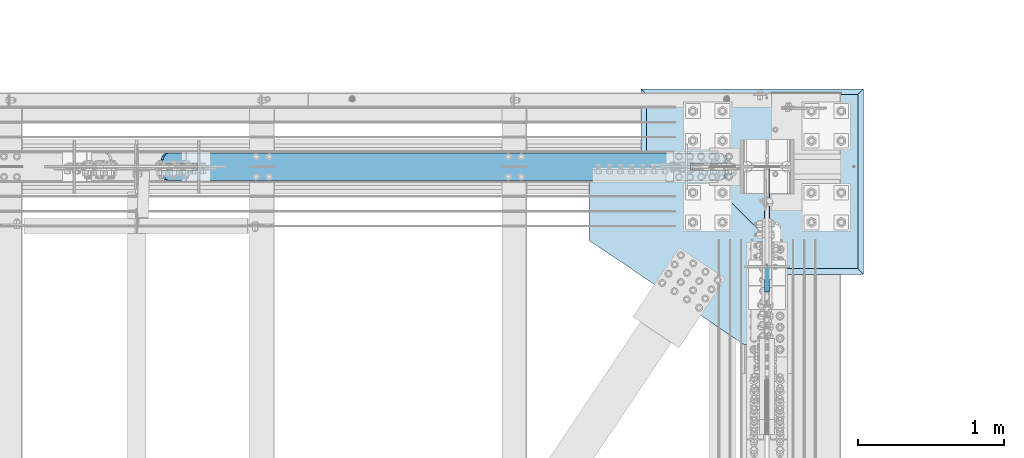
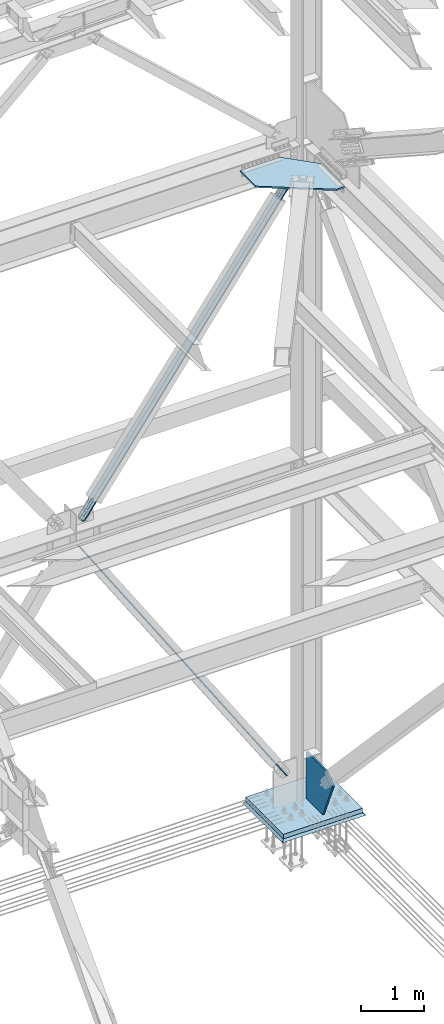
# One storey, part 3007 of 3843: 6 plates, 5 elements without a shape of their own.
"""IFC2X3 building model written with IfcOpenShell, lengths in millimetres."""

from ifc_helpers import new_model, si_unit, frame, origin_with_axes, place, context, subcontext, project, spatial, faceted_brep, material, type_object, element, aggregate, save


model = new_model("IFC2X3")

# Units and contexts
model_context = context("Model", 3, precision=1e-05, world=origin_with_axes())
body_context = subcontext(model_context, "Body", "Model", "MODEL_VIEW")
ifc_project = project(units=[si_unit("LENGTHUNIT", "METRE", prefix="MILLI"), si_unit("AREAUNIT", "SQUARE_METRE"), si_unit("VOLUMEUNIT", "CUBIC_METRE"), si_unit("MASSUNIT", "GRAM", prefix="KILO"), si_unit("TIMEUNIT", "SECOND"), si_unit("PLANEANGLEUNIT", "RADIAN"), si_unit("SOLIDANGLEUNIT", "STERADIAN"), si_unit("THERMODYNAMICTEMPERATUREUNIT", "DEGREE_CELSIUS"), si_unit("LUMINOUSINTENSITYUNIT", "LUMEN")], contexts=[model_context])

# Site, building, storey
site_placement = place(None, origin_with_axes())
site = spatial("IfcSite", under=ifc_project, at=site_placement, CompositionType="ELEMENT")
building_placement = place(site_placement, origin_with_axes())
building = spatial("IfcBuilding", under=site, at=building_placement, Name="Undefined", CompositionType="ELEMENT")
storey_placement = place(building_placement, origin_with_axes())
storey = spatial("IfcBuildingStorey", under=building, at=storey_placement, Name="Undefined", CompositionType="ELEMENT", Elevation=0.0)

# Assembly, plate
assembly_1_placement = place(storey_placement, origin_with_axes())
assembly_1 = element("IfcElementAssembly", 1, at=assembly_1_placement, inside=storey, Name="CB", AssemblyPlace="NOTDEFINED", PredefinedType="RIGID_FRAME")
ifc_material_1 = material(Name="STEEL/A36")
plate_type_1 = type_object("IfcPlateType", PredefinedType="NOTDEFINED")
plate_1_placement = place(assembly_1_placement, frame((81514.0571048379, 104465.4375, 36504.4653808868), z_axis=(0.587657745235489, 0.0, 0.809109618324206), x_axis=(0.0, 1.0, 0.0)))
plate_1 = element("IfcPlate", 2, at=plate_1_placement, type_object=plate_type_1, material=ifc_material_1, Name="CB", context=body_context, shape_type="Brep", body=[
    faceted_brep([(0.0, -9.52500000005239, 71.437499999869), (0.0, -9.52499995547259, 6493.07598148154), (0.0, 9.52500004445756, 6493.07598148161), (0.0, 9.52499999999418, 71.4374999997672), (5.43785589621984, -9.52499995529797, 6520.41392918109), (5.43785589621984, 9.52500004466128, 6520.41392918116), (20.9235593189806, -9.5249999551379, 6543.58992216249), (20.9235593189806, 9.52500004482135, 6543.58992216254), (44.099552300424, -9.52499995502876, 6559.07562558522), (44.099552300424, 9.52500004491594, 6559.07562558529), (71.4375, -9.52499995498511, 6564.51348148144), (71.4375, 9.52500004494505, 6564.51348148151), (71.4375, -9.52499995778635, 6155.63174068234), (71.4375, 9.52500004215108, 6155.63174068239), (115.887500000012, -9.52499995778635, 6155.63174068234), (115.887500000012, 9.52500004215108, 6155.63174068239), (115.887500000012, -9.52499995498511, 6564.51348148144), (115.887500000012, 9.52500004494505, 6564.51348148151), (143.225447699588, -9.52499995502876, 6559.07562558522), (143.225447699588, 9.52500004491594, 6559.07562558529), (166.401440681031, -9.5249999551379, 6543.58992216249), (166.401440681031, 9.52500004482135, 6543.58992216254), (181.887144103792, -9.52499995529797, 6520.41392918109), (181.887144103792, 9.52500004466128, 6520.41392918116), (187.325000000012, -9.52499995547259, 6493.07598148154), (187.325000000012, 9.52500004445756, 6493.07598148161), (187.325000000012, -9.52500000005239, 71.437499999869), (187.325000000012, 9.52499999999418, 71.4374999997672), (181.887144103792, -9.52500000003783, 44.0995523003512), (181.887144103792, 9.52500000001601, 44.0995523002639), (166.401440681031, -9.52500000002328, 20.9235593189806), (166.401440681031, 9.52500000002328, 20.9235593188787), (143.225447699588, -9.52500000002328, 5.4378558962635), (143.225447699588, 9.52500000002328, 5.43785589616164), (115.887500000012, -9.52500000002328, 4.36557456851006e-11), (115.887500000012, 9.52500000002328, -5.82076609134674e-11), (115.887500000012, -9.5250000001397, 408.881740811397), (115.887500000012, 9.52499999990687, 408.88174081131), (71.4375, -9.5250000001397, 408.881740811397), (71.4375, 9.52499999990687, 408.88174081131), (71.4375, -9.52500000002328, 4.36557456851006e-11), (71.4375, 9.52500000002328, -5.82076609134674e-11), (44.099552300424, -9.52500000002328, 5.4378558962635), (44.099552300424, 9.52500000002328, 5.43785589616164), (20.9235593189806, -9.52500000002328, 20.9235593189806), (20.9235593189806, 9.52500000002328, 20.9235593188787), (5.43785589621984, -9.52500000003783, 44.0995523003512), (5.43785589621984, 9.52500000001601, 44.0995523002639)], [[[0, 1, 2, 3]], [[1, 4, 5, 2]], [[4, 6, 7, 5]], [[6, 8, 9, 7]], [[8, 10, 11, 9]], [[10, 12, 13, 11]], [[12, 14, 15, 13]], [[14, 16, 17, 15]], [[16, 18, 19, 17]], [[18, 20, 21, 19]], [[20, 22, 23, 21]], [[22, 24, 25, 23]], [[24, 26, 27, 25]], [[26, 28, 29, 27]], [[28, 30, 31, 29]], [[30, 32, 33, 31]], [[32, 34, 35, 33]], [[34, 36, 37, 35]], [[36, 38, 39, 37]], [[38, 40, 41, 39]], [[40, 42, 43, 41]], [[42, 44, 45, 43]], [[44, 46, 47, 45]], [[46, 0, 3, 47]], [[5, 7, 9, 11, 13, 15, 17, 19, 21, 23, 25, 27, 29, 31, 33, 35, 37, 39, 41, 43, 45, 47, 3, 2]], [[46, 44, 42, 40, 38, 36, 34, 32, 30, 28, 26, 24, 22, 20, 18, 16, 14, 12, 10, 8, 6, 4, 1, 0]]]),
])
aggregate(assembly_1, [plate_1])

assembly_2_placement = place(storey_placement, origin_with_axes())
assembly_2 = element("IfcElementAssembly", 3, at=assembly_2_placement, inside=storey, Name="CB", AssemblyPlace="NOTDEFINED", PredefinedType="RIGID_FRAME")
plate_2_placement = place(assembly_2_placement, frame((85266.1018467478, 104652.7625, 30273.963518513), z_axis=(-0.549839243795952, 0.0, 0.835270498690032), x_axis=(0.0, -1.0, 0.0)))
plate_2 = element("IfcPlate", 4, at=plate_2_placement, type_object=plate_type_1, material=ifc_material_1, Name="CB", context=body_context, shape_type="Brep", body=[
    faceted_brep([(0.0, -9.52500000005239, 71.437499999869), (0.0, -9.5250000347005, 6772.47598159187), (0.0, 9.52499996528059, 6772.47598159185), (0.0, 9.52499999999418, 71.4374999997672), (5.43785589621984, -9.52500003485329, 6799.81392929154), (5.43785589621984, 9.52499996514962, 6799.81392929153), (20.9235593189806, -9.52500003495516, 6822.98992227305), (20.9235593189806, 9.5249999650332, 6822.98992227303), (44.099552300424, -9.52500003503519, 6838.47562569586), (44.099552300424, 9.52499996494589, 6838.47562569585), (71.4375, -9.52500003506429, 6843.91348159211), (71.4375, 9.52499996493134, 6843.9134815921), (71.4375, -9.52500003296154, 6435.03174078606), (71.4375, 9.52499996702682, 6435.03174078604), (115.887500000012, -9.52500003296154, 6435.03174078606), (115.887500000012, 9.52499996702682, 6435.03174078604), (115.887500000012, -9.52500003506429, 6843.91348159211), (115.887500000012, 9.52499996493134, 6843.9134815921), (143.225447699588, -9.52500003503519, 6838.47562569586), (143.225447699588, 9.52499996494589, 6838.47562569585), (166.401440681031, -9.52500003495516, 6822.98992227305), (166.401440681031, 9.5249999650332, 6822.98992227303), (181.887144103792, -9.52500003485329, 6799.81392929154), (181.887144103792, 9.52499996514962, 6799.81392929153), (187.325000000012, -9.5250000347005, 6772.47598159187), (187.325000000012, 9.52499996528059, 6772.47598159185), (187.325000000012, -9.52500000005239, 71.437499999869), (187.325000000012, 9.52499999999418, 71.4374999997672), (181.887144103792, -9.52500000003783, 44.0995523003512), (181.887144103792, 9.52500000001601, 44.0995523002639), (166.401440681031, -9.52500000002328, 20.9235593189806), (166.401440681031, 9.52500000002328, 20.9235593188787), (143.225447699588, -9.52500000002328, 5.4378558962635), (143.225447699588, 9.52500000002328, 5.43785589616164), (115.887500000012, -9.52500000002328, 4.36557456851006e-11), (115.887500000012, 9.52500000002328, -5.82076609134674e-11), (115.887500000012, -9.5250000001397, 408.881740811397), (115.887500000012, 9.52499999990687, 408.88174081131), (71.4375, -9.5250000001397, 408.881740811397), (71.4375, 9.52499999990687, 408.88174081131), (71.4375, -9.52500000002328, 4.36557456851006e-11), (71.4375, 9.52500000002328, -5.82076609134674e-11), (44.099552300424, -9.52500000002328, 5.4378558962635), (44.099552300424, 9.52500000002328, 5.43785589616164), (20.9235593189806, -9.52500000002328, 20.9235593189806), (20.9235593189806, 9.52500000002328, 20.9235593188787), (5.43785589621984, -9.52500000003783, 44.0995523003512), (5.43785589621984, 9.52500000001601, 44.0995523002639)], [[[0, 1, 2, 3]], [[1, 4, 5, 2]], [[4, 6, 7, 5]], [[6, 8, 9, 7]], [[8, 10, 11, 9]], [[10, 12, 13, 11]], [[12, 14, 15, 13]], [[14, 16, 17, 15]], [[16, 18, 19, 17]], [[18, 20, 21, 19]], [[20, 22, 23, 21]], [[22, 24, 25, 23]], [[24, 26, 27, 25]], [[26, 28, 29, 27]], [[28, 30, 31, 29]], [[30, 32, 33, 31]], [[32, 34, 35, 33]], [[34, 36, 37, 35]], [[36, 38, 39, 37]], [[38, 40, 41, 39]], [[40, 42, 43, 41]], [[42, 44, 45, 43]], [[44, 46, 47, 45]], [[46, 0, 3, 47]], [[5, 7, 9, 11, 13, 15, 17, 19, 21, 23, 25, 27, 29, 31, 33, 35, 37, 39, 41, 43, 45, 47, 3, 2]], [[46, 44, 42, 40, 38, 36, 34, 32, 30, 28, 26, 24, 22, 20, 18, 16, 14, 12, 10, 8, 6, 4, 1, 0]]]),
])
aggregate(assembly_2, [plate_2])

assembly_3_placement = place(storey_placement, origin_with_axes())
assembly_3 = element("IfcElementAssembly", 5, at=assembly_3_placement, inside=storey, Name="PLATE", AssemblyPlace="NOTDEFINED", PredefinedType="RIGID_FRAME")
ifc_material_2 = material(Name="STEEL/A572-50")
plate_type_2 = type_object("IfcPlateType", PredefinedType="NOTDEFINED")
plate_3_placement = place(assembly_3_placement, frame((85166.2, 104552.750000036, 42232.2630004883), z_axis=(0.0, -1.0, 0.0), x_axis=(-1.0, 0.0, 0.0)))
plate_3 = element("IfcPlate", 6, at=plate_3_placement, type_object=plate_type_2, material=ifc_material_2, Name="PLATE", context=body_context, shape_type="Brep", body=[
    faceted_brep([(0.0, -14.2874999999985, 0.0), (-476.24999999853, -14.2874999999985, 476.24999999311), (-476.24999999853, 14.2874999999985, 476.24999999311), (0.0, 14.2874999999985, 0.0), (-476.24999999853, -14.2874999999985, 1212.85000000025), (-476.24999999853, 14.2874999999985, 1212.85000000025), (-327.024999999998, -14.2874999999985, 1212.85000000949), (-327.024999999998, 14.2874999999985, 1212.85000000949), (736.599999999977, -14.2874999999985, 499.389608647441), (736.599999999977, 14.2874999999985, 499.389608647441), (736.599999940488, -14.2874999999985, 0.0), (736.599999940488, 14.2874999999985, 0.0)], [[[0, 1, 2, 3]], [[1, 4, 5, 2]], [[4, 6, 7, 5]], [[6, 8, 9, 7]], [[8, 10, 11, 9]], [[10, 0, 3, 11]], [[5, 7, 9, 11, 3, 2]], [[10, 8, 6, 4, 1, 0]]]),
])
aggregate(assembly_3, [plate_3])

assembly_4_placement = place(storey_placement, origin_with_axes())
assembly_4 = element("IfcElementAssembly", 7, at=assembly_4_placement, inside=storey, Name="COLUMN", AssemblyPlace="NOTDEFINED", PredefinedType="RIGID_FRAME")
plate_type_3 = type_object("IfcPlateType", PredefinedType="NOTDEFINED")
plate_4_placement = place(assembly_4_placement, frame((85648.8, 104551.95625, 29692.6), z_axis=(0.0, 0.0, 1.0), x_axis=(0.0, -1.0, 0.0)))
plate_4 = element("IfcPlate", 8, at=plate_4_placement, type_object=plate_type_3, material=ifc_material_2, Name="CB", context=body_context, shape_type="Brep", body=[
    faceted_brep([(0.0, -15.875, 19.0499992370605), (0.0, -15.875, 888.895145418875), (0.0, 15.875, 888.895145418875), (0.0, 15.875, 19.0499992370605), (19.0499992370605, -15.875, 907.945144655936), (19.0499992370605, 15.875, 907.945144655936), (663.438174577459, -15.875, 907.945144655936), (663.438174577459, 15.875, 907.945144655936), (849.920742003465, -15.875, 732.47461633704), (849.920742003465, 15.875, 732.47461633704), (533.399999999994, -15.875, 0.0), (533.399999999994, 15.875, 0.0), (19.0500015258804, -15.875, 0.0), (19.0500015258804, 15.875, 0.0)], [[[0, 1, 2, 3]], [[1, 4, 5, 2]], [[4, 6, 7, 5]], [[6, 8, 9, 7]], [[8, 10, 11, 9]], [[10, 12, 13, 11]], [[12, 0, 3, 13]], [[5, 7, 9, 11, 13, 3, 2]], [[12, 10, 8, 6, 4, 1, 0]]]),
])

assembly_5_placement = place(storey_placement, origin_with_axes())
assembly_5 = element("IfcElementAssembly", 9, at=assembly_5_placement, inside=storey, Name="GROUT", AssemblyPlace="NOTDEFINED", PredefinedType="REINFORCEMENT_UNIT")
ifc_material_3 = material(Name="CONCRETE/Concrete_Undefined")
plate_type_4 = type_object("IfcPlateType", PredefinedType="NOTDEFINED")
plate_5_placement = place(assembly_5_placement, frame((84785.2, 103822.5, 29584.65), z_axis=(0.0, 1.0, 0.0), x_axis=(1.0, 0.0, 0.0)))
plate_5 = element("IfcPlate", 10, at=plate_5_placement, type_object=plate_type_4, material=ifc_material_3, Name="GROUT", context=body_context, shape_type="Brep", body=[
    faceted_brep([(38.1000000006898, -19.0499999997774, 1231.89999999931), (0.0, 19.0499999999993, 1270.0), (0.0, 19.0500000000029, 0.0), (38.1000000006916, -19.0499999999811, 38.1000000006607), (1485.89999999932, -19.0499999997955, 38.1000000006752), (1524.0, 19.0499999999993, 0.0), (1524.0, 19.0499999999993, 1270.0), (1485.89999999932, -19.049999999992, 1231.89999999931)], [[[0, 1, 2, 3]], [[4, 5, 6, 7]], [[4, 7, 0, 3]], [[5, 4, 3, 2]], [[6, 5, 2, 1]], [[7, 6, 1, 0]]]),
])
aggregate(assembly_5, [plate_5])

# Plate
plate_type_5 = type_object("IfcPlateType", PredefinedType="NOTDEFINED")
plate_6_placement = place(assembly_4_placement, frame((84823.3, 103860.6, 29648.15), z_axis=(0.0, 1.0, 0.0), x_axis=(1.0, 0.0, 0.0)))
plate_6 = element("IfcPlate", 11, at=plate_6_placement, type_object=plate_type_5, material=ifc_material_2, Name="PLATE", context=body_context, shape_type="Brep", body=[
    faceted_brep([(0.0, -44.4500000000007, 0.0), (0.0, -44.4500000000007, 1193.80004882812), (0.0, 44.4500000000007, 1193.80004882812), (0.0, 44.4500000000007, 0.0), (1447.80004882812, -44.4500000000007, 1193.80004882812), (1447.80004882812, 44.4500000000007, 1193.80004882812), (1447.80004882812, -44.4500000000007, 0.0), (1447.80004882812, 44.4500000000007, 0.0)], [[[0, 1, 2, 3]], [[1, 4, 5, 2]], [[4, 6, 7, 5]], [[6, 0, 3, 7]], [[5, 7, 3, 2]], [[6, 4, 1, 0]]]),
])

aggregate(assembly_4, [plate_4, plate_6])

save(model, "model.ifc")
